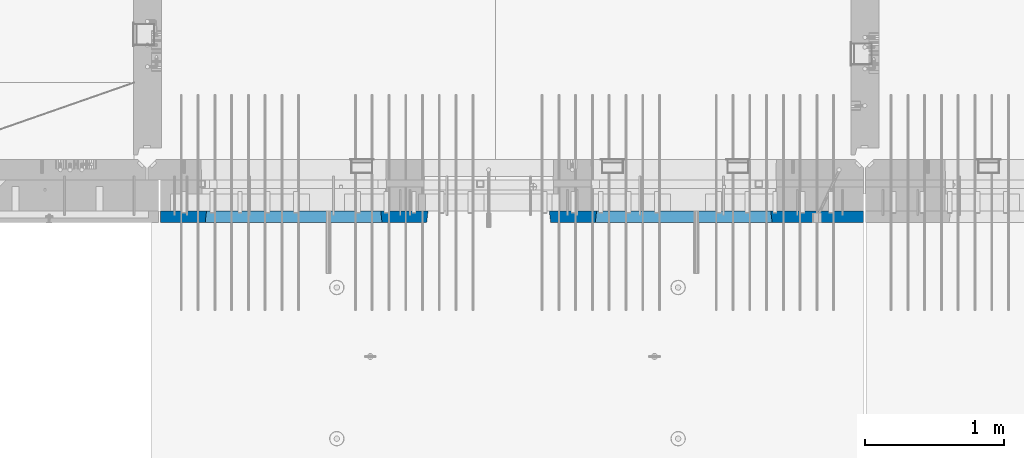
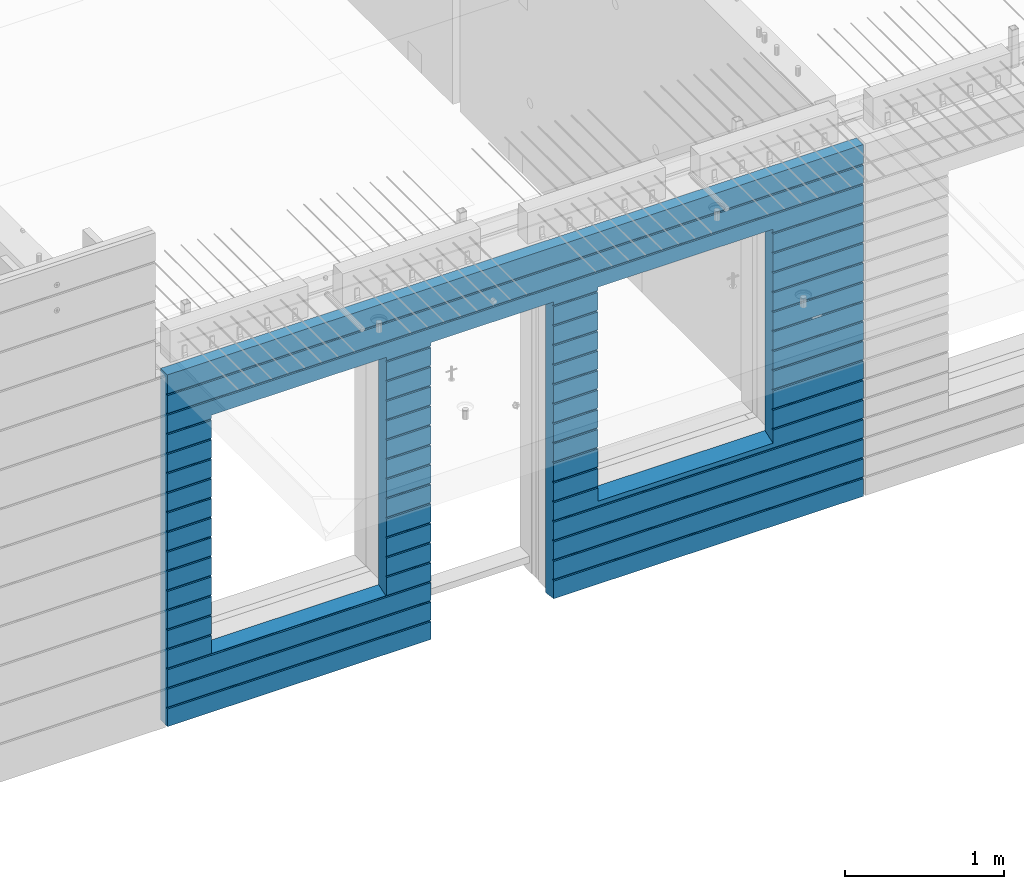
# One storey, part 196 of 309: 1 wall, 1 element without a shape of its own.
"""IFC2X3 building model written with IfcOpenShell, lengths in millimetres."""

from ifc_helpers import new_model, si_unit, frame, origin_with_axes, place, context, subcontext, project, spatial, faceted_brep, material, type_object, element, aggregate, save


model = new_model("IFC2X3")

# Units and contexts
model_context = context("Model", 3, precision=1e-05, world=origin_with_axes())
body_context = subcontext(model_context, "Body", "Model", "MODEL_VIEW")
ifc_project = project(units=[si_unit("LENGTHUNIT", "METRE", prefix="MILLI"), si_unit("AREAUNIT", "SQUARE_METRE"), si_unit("VOLUMEUNIT", "CUBIC_METRE"), si_unit("MASSUNIT", "GRAM", prefix="KILO"), si_unit("TIMEUNIT", "SECOND"), si_unit("PLANEANGLEUNIT", "RADIAN"), si_unit("SOLIDANGLEUNIT", "STERADIAN"), si_unit("THERMODYNAMICTEMPERATUREUNIT", "DEGREE_CELSIUS"), si_unit("LUMINOUSINTENSITYUNIT", "LUMEN")], contexts=[model_context])

# Site, building, storey
site_placement = place(None, origin_with_axes())
site = spatial("IfcSite", under=ifc_project, at=site_placement, CompositionType="ELEMENT")
building_placement = place(site_placement, origin_with_axes())
building = spatial("IfcBuilding", under=site, at=building_placement, CompositionType="ELEMENT")
storey_placement = place(building_placement, origin_with_axes())
storey = spatial("IfcBuildingStorey", under=building, at=storey_placement, Name="7", CompositionType="ELEMENT", Elevation=0.0)

# Assembly, wall
assembly_placement = place(storey_placement, origin_with_axes())
assembly = element("IfcElementAssembly", 1, at=assembly_placement, inside=storey, AssemblyPlace="NOTDEFINED", PredefinedType="REINFORCEMENT_UNIT")
ifc_material = material(Name="CONCRETE/C30/37")
wall_type = type_object("IfcWallType", PredefinedType="NOTDEFINED")
wall_placement = place(assembly_placement, frame((21810.0, 7587.5, 101102.5), z_axis=(0.0, 0.0, 1.0), x_axis=(-1.0, 3.00000001838171e-08, 0.0)))
wall = element("IfcWall", 2, at=wall_placement, type_object=wall_type, material=ifc_material, context=body_context, shape_type="Brep", body=[
    faceted_brep([(3465.15088791894, 41.2121213860573, -911.742424344746), (3464.99937278789, 42.5, -912.5), (3464.99937278789, 42.5, -912.000000055254), (4734.84785765683, 41.2121213860573, -911.742424344746), (4734.99937278789, 42.5, -912.5), (4734.99937278789, 42.5, -912.000000055254), (10.0, 42.5, -1347.5), (10.0, 42.5, -1212.00000005524), (2254.99845837354, 42.5, -1212.00000005524), (2254.99845837354, 42.5, -1347.5), (10.0, 32.4999992501662, -1210.00000000079), (2256.17512512844, 32.4999992501662, -1210.00000000079), (10.0000007500639, 32.499999249937, -1200.00000000079), (2256.17512514468, 32.4999991121731, -1199.99999959956), (10.0, 42.5, -1198.00000011075), (2254.99845837354, 42.5, -1198.00000011075), (10.0, 42.5, -1062.00000005522), (2254.99845837354, 42.5, -1062.00000005522), (10.0, 32.4999992506964, -1060.00000000079), (2256.17512512838, 32.4999992506964, -1060.00000000079), (10.0000007500657, 32.499999249937, -1050.00000000079), (2256.17512514461, 32.499999112697, -1049.99999959956), (10.0, 42.5, -1048.00000011074), (2254.99845837354, 42.5, -1048.00000011074), (10.0, 42.5, -912.000000055254), (2254.99845837354, 42.5, -912.000000055254), (10.0, 32.4999992512312, -910.000000000815), (2256.17512512832, 32.4999992512312, -910.000000000815), (10.0000007500657, 32.499999249937, -900.000000000786), (2256.17512514455, 32.4999991132318, -899.99999959959), (10.0, 42.5, -898.000000110769), (2254.99845837354, 42.5, -898.000000110769), (10.0, 42.5, -762.000000055225), (2254.99845837354, 42.5, -762.000000055225), (10.0, 32.4999992517696, -760.000000000771), (2256.17512512825, 32.4999992517696, -760.000000000771), (10.0000007500657, 32.499999249937, -750.000000000786), (2256.17512514449, 32.4999991137747, -749.999999599546), (10.0, 42.5, -748.00000011074), (2254.99845837354, 42.5, -748.00000011074), (675.00013572734, 42.5, 927.5), (1925.00013572734, 42.5, 927.5), (1935.00013572734, 42.5, 927.5), (1925.00013572734, -42.5, 932.5), (675.00013572734, -42.5, 932.5), (665.00013572734, 42.5, 927.5), (665.00013572734, 42.5, -712.5), (675.00013572734, -42.5, -662.5), (1925.00013572734, -42.5, -662.5), (1935.00013572734, 42.5, -712.5), (1925.00013572734, -42.5, 927.5), (1935.00013572734, 42.5, 901.999999889245), (1933.82366503463, 32.4999991119776, 900.000000400425), (1933.82366505087, 32.4999992499834, 889.9999999992), (1935.00013572734, 42.5, 887.999999944761), (1935.00013572734, 42.5, 751.999999889245), (1933.82366503463, 32.4999991119885, 750.000000400425), (1933.82366505087, 32.4999992499925, 739.9999999992), (1935.00013572734, 42.5, 737.999999944761), (1935.00013572734, 42.5, 601.99999988926), (1933.82366503463, 32.4999991120112, 600.00000040044), (1933.82366505087, 32.4999992500152, 589.999999999214), (1935.00013572734, 42.5, 587.999999944775), (1935.00013572734, 42.5, 451.999999889245), (1933.82366503464, 32.4999991120167, 450.000000400425), (1933.82366505087, 32.4999992500216, 439.9999999992), (1935.00013572734, 42.5, 437.999999944761), (1935.00013572734, 42.5, 301.999999889245), (1933.82366503464, 32.4999991120312, 300.000000400425), (1933.82366505087, 32.4999992500352, 289.9999999992), (1935.00013572734, 42.5, 287.999999944761), (1935.00013572734, 42.5, 151.999999889245), (1933.82366503464, 32.4999991120421, 150.000000400425), (1933.82366505088, 32.499999250047, 139.9999999992), (1935.00013572734, 42.5, 137.999999944761), (1935.00013572734, 42.5, 1.99999988923082), (1933.82366503515, 32.4999991164286, 4.00410499423742e-07), (1933.82366505139, 32.4999992544263, -10.0000000008149), (1935.00013572734, 42.5, -12.0000000552536), (1935.00013572734, 42.5, -148.000000110755), (1933.82366503509, 32.4999991158993, -149.99999959956), (1933.82366505132, 32.4999992538915, -160.000000000786), (1935.00013572734, 42.5, -162.000000055239), (1935.00013572734, 42.5, -298.000000110755), (1933.82366503503, 32.49999911536, -299.999999599575), (1933.82366505126, 32.4999992533594, -310.0000000008), (1935.00013572734, 42.5, -312.000000055239), (1935.00013572734, 42.5, -448.00000011074), (1933.82366503496, 32.4999991148343, -449.99999959956), (1933.8236650512, 32.4999992528337, -460.000000000786), (1935.00013572734, 42.5, -462.000000055225), (1935.00013572734, 42.5, -598.000000110755), (1933.8236650349, 32.499999114295, -599.999999599575), (1933.82366505114, 32.4999992522935, -610.0000000008), (1935.00013572734, 42.5, -612.000000055239), (2256.1751251447, 32.4999991119776, 900.000000400425), (2256.17512512846, 32.4999992499834, 889.9999999992), (2254.99845837354, 42.5, 887.999999944761), (2254.99845837354, 42.5, 751.999999889245), (2256.17512514469, 32.4999991119885, 750.000000400425), (2256.17512512846, 32.4999992499925, 739.9999999992), (2254.99845837354, 42.5, 737.999999944761), (2254.99845837354, 42.5, 601.99999988926), (2256.17512514469, 32.4999991120112, 600.00000040044), (2256.17512512846, 32.4999992500152, 589.999999999214), (2254.99845837354, 42.5, 587.999999944775), (2254.99845837354, 42.5, 451.999999889245), (2256.17512514469, 32.4999991120167, 450.000000400425), (2256.17512512846, 32.4999992500216, 439.9999999992), (2254.99845837354, 42.5, 437.999999944761), (2254.99845837354, 42.5, 301.999999889245), (2256.17512514469, 32.4999991120312, 300.000000400425), (2256.17512512846, 32.4999992500352, 289.9999999992), (2254.99845837354, 42.5, 287.999999944761), (2254.99845837354, 42.5, 151.999999889245), (2256.17512514469, 32.4999991120421, 150.000000400425), (2256.17512512846, 32.499999250047, 139.9999999992), (2254.99845837354, 42.5, 137.999999944761), (2254.99845837354, 42.5, 1.99999988923082), (2256.17512514417, 32.4999991164286, 4.00410499423742e-07), (2256.17512512794, 32.4999992544263, -10.0000000008149), (2254.99845837354, 42.5, -12.0000000552536), (2254.99845837354, 42.5, -148.000000110755), (2256.17512514424, 32.4999991158993, -149.99999959956), (2256.175125128, 32.4999992538915, -160.000000000786), (2254.99845837354, 42.5, -162.000000055239), (2254.99845837354, 42.5, -298.000000110755), (2256.1751251443, 32.49999911536, -299.999999599575), (2256.17512512806, 32.4999992533594, -310.0000000008), (2254.99845837354, 42.5, -312.000000055239), (2254.99845837354, 42.5, -448.00000011074), (2256.17512514436, 32.4999991148343, -449.99999959956), (2256.17512512813, 32.4999992528337, -460.000000000786), (2254.99845837354, 42.5, -462.000000055225), (2254.99845837354, 42.5, -598.000000110755), (2256.17512514443, 32.499999114295, -599.999999599575), (2256.17512512819, 32.4999992522935, -610.0000000008), (2254.99845837354, 42.5, -612.000000055239), (10.0, 42.5, -612.000000055239), (665.00013572734, 42.5, -612.000000055239), (10.0, 32.4999992522935, -610.0000000008), (666.176606403544, 32.4999992522935, -610.0000000008), (10.0000007500657, 32.499999249937, -600.000000000786), (666.176606419776, 32.499999114295, -599.999999599575), (10.0, 42.5, -598.000000110755), (665.00013572734, 42.5, -598.000000110755), (10.0, 42.5, -462.000000055225), (665.00013572734, 42.5, -462.000000055225), (10.0, 32.4999992528337, -460.000000000786), (666.176606403482, 32.4999992528337, -460.000000000786), (10.0000007500657, 32.499999249937, -450.000000000786), (666.176606419715, 32.4999991148343, -449.99999959956), (10.0, 42.5, -448.00000011074), (665.00013572734, 42.5, -448.00000011074), (10.0, 42.5, -312.000000055239), (665.00013572734, 42.5, -312.000000055239), (10.0, 32.4999992533594, -310.0000000008), (666.17660640342, 32.4999992533594, -310.0000000008), (10.0000007500657, 32.499999249937, -300.000000000786), (666.176606419653, 32.49999911536, -299.999999599575), (10.0, 42.5, -298.000000110755), (665.00013572734, 42.5, -298.000000110755), (10.0, 42.5, -162.000000055239), (665.00013572734, 42.5, -162.000000055239), (10.0, 32.4999992538915, -160.000000000786), (666.176606403355, 32.4999992538915, -160.000000000786), (10.0000007500657, 32.499999249937, -150.000000000786), (666.176606419591, 32.4999991158993, -149.99999959956), (10.0, 42.5, -148.000000110755), (665.00013572734, 42.5, -148.000000110755), (10.0, 42.5, -12.0000000552536), (665.00013572734, 42.5, -12.0000000552536), (10.0, 32.4999992544263, -10.0000000008149), (666.176606403293, 32.4999992544263, -10.0000000008149), (10.0000007500657, 32.499999249937, -7.8580342233181e-10), (666.176606419529, 32.4999991164286, 4.00410499423742e-07), (10.0, 42.5, 1.99999988923082), (665.00013572734, 42.5, 1.99999988923082), (10.0, 42.5, 137.999999944761), (665.00013572734, 42.5, 137.999999944761), (10.0, 32.499999250047, 139.9999999992), (666.176606403806, 32.499999250047, 139.9999999992), (10.0000007500657, 32.499999249937, 149.999999999214), (666.176606420046, 32.4999991120421, 150.000000400425), (10.0, 42.5, 151.999999889245), (665.00013572734, 42.5, 151.999999889245), (10.0, 42.5, 287.999999944761), (665.00013572734, 42.5, 287.999999944761), (10.0, 32.4999992500352, 289.9999999992), (666.176606403809, 32.4999992500352, 289.9999999992), (10.0000007500657, 32.499999249937, 299.999999999214), (666.176606420046, 32.4999991120312, 300.000000400425), (10.0, 42.5, 301.999999889245), (665.00013572734, 42.5, 301.999999889245), (10.0, 42.5, 437.999999944761), (665.00013572734, 42.5, 437.999999944761), (10.0, 32.4999992500216, 439.9999999992), (666.176606403809, 32.4999992500216, 439.9999999992), (10.0000007500657, 32.499999249937, 449.999999999214), (666.176606420046, 32.4999991120167, 450.000000400425), (10.0, 42.5, 451.999999889245), (665.00013572734, 42.5, 451.999999889245), (10.0, 42.5, 587.999999944775), (665.00013572734, 42.5, 587.999999944775), (10.0, 32.4999992500152, 589.999999999214), (666.176606403809, 32.4999992500152, 589.999999999214), (10.0000007500657, 32.499999249937, 599.999999999214), (666.176606420049, 32.4999991120112, 600.00000040044), (10.0, 42.5, 601.99999988926), (665.00013572734, 42.5, 601.99999988926), (10.0, 42.5, 737.999999944761), (665.00013572734, 42.5, 737.999999944761), (9.99999999999636, 32.4999992499925, 739.9999999992), (666.176606403813, 32.4999992499925, 739.9999999992), (10.0000007500657, 32.499999249937, 749.999999999214), (666.176606420049, 32.4999991119885, 750.000000400425), (10.0, 42.5, 751.999999889245), (665.00013572734, 42.5, 751.999999889245), (10.0, 42.5, 887.999999944761), (665.00013572734, 42.5, 887.999999944761), (10.0, 32.4999992499834, 889.9999999992), (666.176606403813, 32.4999992499834, 889.9999999992), (10.0000007500657, 32.499999249937, 899.999999999214), (666.176606420053, 32.4999991119776, 900.000000400425), (675.00013572734, -42.5, 927.5), (665.00013572734, 42.5, 901.999999889245), (10.0, 42.5, 901.999999889245), (10.0, 42.5, 1051.99999988925), (5055.0, 42.5, 1051.99999988925), (5055.0, 32.4999991119666, 1050.00000040043), (10.0000007500657, 32.499999249937, 1049.99999999921), (5055.0, 32.4999992499706, 1039.9999999992), (10.0, 32.4999992499706, 1039.9999999992), (5055.0, 42.5, 1037.99999994476), (10.0, 42.5, 1037.99999994476), (5055.0, 42.5, 901.999999889245), (5055.0, 32.4999991119776, 900.000000400425), (4733.82290209518, 32.4999991119776, 900.000000400425), (4734.99937278789, 42.5, 901.999999889245), (5055.0, 32.4999992499834, 889.9999999992), (4733.82290211141, 32.4999992499834, 889.9999999992), (5055.0, 42.5, 887.999999944761), (4734.99937278789, 42.5, 887.999999944761), (5055.0, 42.5, 751.999999889245), (4734.99937278789, 42.5, 751.999999889245), (5055.0, 32.4999991119885, 750.000000400425), (4733.82290209518, 32.4999991119885, 750.000000400425), (5055.0, 32.4999992499925, 739.9999999992), (4733.82290211142, 32.4999992499925, 739.9999999992), (5055.0, 42.5, 737.999999944761), (4734.99937278789, 42.5, 737.999999944761), (5055.0, 42.5, 601.99999988926), (4734.99937278789, 42.5, 601.99999988926), (5055.0, 32.4999991120112, 600.00000040044), (4733.82290209518, 32.4999991120112, 600.00000040044), (5055.0, 32.4999992500152, 589.999999999214), (4733.82290211142, 32.4999992500152, 589.999999999214), (5055.0, 42.5, 587.999999944775), (4734.99937278789, 42.5, 587.999999944775), (5055.0, 42.5, 451.999999889245), (4734.99937278789, 42.5, 451.999999889245), (5055.0, 32.4999991120167, 450.000000400425), (4733.82290209518, 32.4999991120167, 450.000000400425), (5055.0, 32.4999992500216, 439.9999999992), (4733.82290211142, 32.4999992500216, 439.9999999992), (5055.0, 42.5, 437.999999944761), (4734.99937278789, 42.5, 437.999999944761), (5055.0, 42.5, 301.999999889245), (4734.99937278789, 42.5, 301.999999889245), (5055.0, 32.4999991120312, 300.000000400425), (4733.82290209518, 32.4999991120312, 300.000000400425), (5055.0, 32.4999992500352, 289.9999999992), (4733.82290211142, 32.4999992500352, 289.9999999992), (5055.0, 42.5, 287.999999944761), (4734.99937278789, 42.5, 287.999999944761), (5055.0, 42.5, 151.999999889245), (4734.99937278789, 42.5, 151.999999889245), (5055.0, 32.4999991120421, 150.000000400425), (4733.82290209519, 32.4999991120421, 150.000000400425), (5055.0, 32.499999250047, 139.9999999992), (4733.82290211142, 32.499999250047, 139.9999999992), (5055.0, 42.5, 137.999999944761), (4734.99937278789, 42.5, 137.999999944761), (5055.0, 42.5, 1.99999988923082), (4734.99937278789, 42.5, 1.99999988923082), (5055.0, 32.4999991164286, 4.00410499423742e-07), (4733.8229020957, 32.4999991164286, 4.00410499423742e-07), (5055.0, 32.4999992544263, -10.0000000008149), (4733.82290211194, 32.4999992544263, -10.0000000008149), (5055.0, 42.5, -12.0000000552536), (4734.99937278789, 42.5, -12.0000000552536), (5055.0, 42.5, -148.000000110755), (4734.99937278789, 42.5, -148.000000110755), (5055.0, 32.4999991158993, -149.99999959956), (4733.82290209564, 32.4999991158993, -149.99999959956), (5055.0, 32.4999992538915, -160.000000000786), (4733.82290211188, 32.4999992538915, -160.000000000786), (5055.0, 42.5, -162.000000055239), (4734.99937278789, 42.5, -162.000000055239), (5055.0, 42.5, -298.000000110755), (4734.99937278789, 42.5, -298.000000110755), (5055.0, 32.49999911536, -299.999999599575), (4733.82290209558, 32.49999911536, -299.999999599575), (5055.0, 32.4999992533594, -310.0000000008), (4733.82290211181, 32.4999992533594, -310.0000000008), (5055.0, 42.5, -312.000000055239), (4734.99937278789, 42.5, -312.000000055239), (5055.0, 42.5, -448.00000011074), (4734.99937278789, 42.5, -448.00000011074), (5055.0, 32.4999991148343, -449.99999959956), (4733.82290209552, 32.4999991148343, -449.99999959956), (5055.0, 32.4999992528337, -460.000000000786), (4733.82290211175, 32.4999992528337, -460.000000000786), (5055.0, 42.5, -462.000000055225), (4734.99937278789, 42.5, -462.000000055225), (5055.0, 42.5, -598.000000110755), (4734.99937278789, 42.5, -598.000000110755), (5055.0, 32.499999114295, -599.999999599575), (4733.82290209545, 32.499999114295, -599.999999599575), (5055.0, 32.4999992522935, -610.0000000008), (4733.82290211169, 32.4999992522935, -610.0000000008), (5055.0, 42.5, -612.000000055239), (4734.99937278789, 42.5, -612.000000055239), (5055.0, 42.5, -748.00000011074), (4734.99937278789, 42.5, -748.00000011074), (5055.0, 32.4999991137747, -749.999999599546), (4733.82290209539, 32.4999991137747, -749.999999599546), (5055.0, 32.4999992517696, -760.000000000771), (4733.82290211162, 32.4999992517696, -760.000000000771), (5055.0, 42.5, -762.000000055225), (4734.99937278789, 42.5, -762.000000055225), (5055.0, 42.5, -898.000000110769), (4734.99937278789, 42.5, -898.000000110769), (5055.0, 32.4999991132318, -899.99999959959), (4733.82290209533, 32.4999991132318, -899.99999959959), (3466.1758434697, 32.499999204555, -906.617646590923), (3474.99937278789, -42.5, -862.5), (4724.99937278789, -42.5, -862.5), (4733.82290210607, 32.499999204555, -906.617646590923), (4724.99937278789, -42.5, 927.5), (4724.99937278789, -42.5, 932.5), (4734.99937278789, 42.5, 927.5), (2265.00051719707, 42.5, 927.5), (3135.00051719707, 42.5, 927.5), (3144.99845837354, 42.5, 927.5), (3134.99679170688, -42.5, 932.502857142856), (2265.00012504021, -42.5, 932.502857142856), (2254.99845837354, 42.5, 927.5), (4724.99937278789, 42.5, 927.5), (3474.99937278789, 42.5, 927.5), (3464.99937278789, 42.5, 927.5), (3464.99937278789, 42.5, 901.999999889245), (3144.99845837354, 42.5, 901.999999889245), (2254.99845837354, 42.5, 901.999999889245), (2265.00012504021, -42.5, 927.5), (2265.00012504021, -42.5, -1347.5), (10.0, -42.5, -1347.5), (10.0, 42.5, 1347.5), (10.0, -42.5, 1347.5), (5055.0, -42.5, 1347.5), (5055.0, 42.5, 1347.5), (5055.0, 42.5, 1201.99999988925), (10.0, 42.5, 1201.99999988925), (10.0, 42.5, 1187.99999994476), (10.0000007500657, 32.499999249937, 1199.99999999921), (9.99999999999636, 32.4999992499606, 1189.9999999992), (5055.0, 42.5, 1187.99999994476), (5055.0, 32.4999992499606, 1189.9999999992), (5055.0, 32.4999991119566, 1200.00000040043), (5055.0, -42.5, -1347.5), (5055.0, 42.5, -1347.5), (5055.0, 42.5, -1212.00000005524), (5055.0, 32.4999992501662, -1210.00000000079), (5055.0, 32.4999991121731, -1199.99999959956), (5055.0, 42.5, -1198.00000011075), (5055.0, 42.5, -1062.00000005522), (5055.0, 32.4999992506964, -1060.00000000079), (5055.0, 32.499999112697, -1049.99999959956), (5055.0, 42.5, -1048.00000011074), (5055.0, 42.5, -912.000000055254), (5055.0, 32.4999992512312, -910.000000000815), (3144.99845837354, 42.5, -1212.00000005524), (3143.82179161865, 32.4999992501662, -1210.00000000079), (3143.82179160241, 32.4999991121731, -1199.99999959956), (3144.99845837354, 42.5, -1198.00000011075), (3144.99845837354, 42.5, -1062.00000005522), (3143.82179161871, 32.4999992506964, -1060.00000000079), (3143.82179160247, 32.499999112697, -1049.99999959956), (3144.99845837354, 42.5, -1048.00000011074), (3144.99845837354, 42.5, -912.000000055254), (3143.82179161877, 32.4999992512312, -910.000000000815), (3466.17584348045, 32.4999991132318, -899.99999959959), (3143.82179160253, 32.4999991132318, -899.99999959959), (3464.99937278789, 42.5, -898.000000110769), (3144.99845837354, 42.5, -898.000000110769), (3464.99937278789, 42.5, -762.000000055225), (3144.99845837354, 42.5, -762.000000055225), (3466.17584346415, 32.4999992517696, -760.000000000771), (3143.82179161884, 32.4999992517696, -760.000000000771), (3466.17584348039, 32.4999991137747, -749.999999599546), (3143.8217916026, 32.4999991137747, -749.999999599546), (3464.99937278789, 42.5, -748.00000011074), (3144.99845837354, 42.5, -748.00000011074), (3464.99937278789, 42.5, -612.000000055239), (3144.99845837354, 42.5, -612.000000055239), (3466.17584346409, 32.4999992522935, -610.0000000008), (3143.8217916189, 32.4999992522935, -610.0000000008), (3466.17584348032, 32.499999114295, -599.999999599575), (3143.82179160266, 32.499999114295, -599.999999599575), (3464.99937278789, 42.5, -598.000000110755), (3144.99845837354, 42.5, -598.000000110755), (3464.99937278789, 42.5, -462.000000055225), (3144.99845837354, 42.5, -462.000000055225), (3466.17584346403, 32.4999992528337, -460.000000000786), (3143.82179161896, 32.4999992528337, -460.000000000786), (3466.17584348026, 32.4999991148343, -449.99999959956), (3143.82179160272, 32.4999991148343, -449.99999959956), (3464.99937278789, 42.5, -448.00000011074), (3144.99845837354, 42.5, -448.00000011074), (3464.99937278789, 42.5, -312.000000055239), (3144.99845837354, 42.5, -312.000000055239), (3466.17584346396, 32.4999992533594, -310.0000000008), (3143.82179161902, 32.4999992533594, -310.0000000008), (3466.1758434802, 32.49999911536, -299.999999599575), (3143.82179160278, 32.49999911536, -299.999999599575), (3464.99937278789, 42.5, -298.000000110755), (3144.99845837354, 42.5, -298.000000110755), (3464.99937278789, 42.5, -162.000000055239), (3144.99845837354, 42.5, -162.000000055239), (3466.1758434639, 32.4999992538915, -160.000000000786), (3143.82179161909, 32.4999992538915, -160.000000000786), (3466.17584348014, 32.4999991158993, -149.99999959956), (3143.82179160284, 32.4999991158993, -149.99999959956), (3464.99937278789, 42.5, -148.000000110755), (3144.99845837354, 42.5, -148.000000110755), (3464.99937278789, 42.5, -12.0000000552536), (3144.99845837354, 42.5, -12.0000000552536), (3466.17584346384, 32.4999992544263, -10.0000000008149), (3143.82179161915, 32.4999992544263, -10.0000000008149), (3466.17584348008, 32.4999991164286, 4.00410499423742e-07), (3143.82179160291, 32.4999991164286, 4.00410499423742e-07), (3464.99937278789, 42.5, 1.99999988923082), (3144.99845837354, 42.5, 1.99999988923082), (3464.99937278789, 42.5, 137.999999944761), (3144.99845837354, 42.5, 137.999999944761), (3466.17584346435, 32.499999250047, 139.9999999992), (3143.82179161863, 32.499999250047, 139.9999999992), (3466.17584348059, 32.4999991120421, 150.000000400425), (3143.82179160239, 32.4999991120421, 150.000000400425), (3464.99937278789, 42.5, 151.999999889245), (3144.99845837354, 42.5, 151.999999889245), (3464.99937278789, 42.5, 287.999999944761), (3144.99845837354, 42.5, 287.999999944761), (3466.17584346436, 32.4999992500352, 289.9999999992), (3143.82179161863, 32.4999992500352, 289.9999999992), (3466.17584348059, 32.4999991120312, 300.000000400425), (3143.82179160239, 32.4999991120312, 300.000000400425), (3464.99937278789, 42.5, 301.999999889245), (3144.99845837354, 42.5, 301.999999889245), (3464.99937278789, 42.5, 437.999999944761), (3144.99845837354, 42.5, 437.999999944761), (3466.17584346436, 32.4999992500216, 439.9999999992), (3143.82179161863, 32.4999992500216, 439.9999999992), (3466.17584348059, 32.4999991120167, 450.000000400425), (3143.82179160239, 32.4999991120167, 450.000000400425), (3464.99937278789, 42.5, 451.999999889245), (3144.99845837354, 42.5, 451.999999889245), (3464.99937278789, 42.5, 587.999999944775), (3144.99845837354, 42.5, 587.999999944775), (3466.17584346436, 32.4999992500152, 589.999999999214), (3143.82179161863, 32.4999992500152, 589.999999999214), (3466.1758434806, 32.4999991120112, 600.00000040044), (3143.82179160239, 32.4999991120112, 600.00000040044), (3464.99937278789, 42.5, 601.99999988926), (3144.99845837354, 42.5, 601.99999988926), (3464.99937278789, 42.5, 737.999999944761), (3144.99845837354, 42.5, 737.999999944761), (3466.17584346436, 32.4999992499925, 739.9999999992), (3143.82179161863, 32.4999992499925, 739.9999999992), (3466.1758434806, 32.4999991119885, 750.000000400425), (3143.82179160239, 32.4999991119885, 750.000000400425), (3464.99937278789, 42.5, 751.999999889245), (3144.99845837354, 42.5, 751.999999889245), (3464.99937278789, 42.5, 887.999999944761), (3144.99845837354, 42.5, 887.999999944761), (3466.17584346436, 32.4999992499834, 889.9999999992), (3143.82179161863, 32.4999992499834, 889.9999999992), (3466.1758434806, 32.4999991119776, 900.000000400425), (3143.82179160239, 32.4999991119776, 900.000000400425), (3474.99937278789, -42.5, 932.5), (3474.99937278789, -42.5, 927.5), (3134.99679170688, -42.5, 927.5), (3134.99679170688, -42.5, -1347.5), (3144.99845837354, 42.5, -1347.5)], [[[0, 1, 2]], [[3, 4, 1, 0]], [[5, 4, 3]], [[6, 7, 8, 9]], [[7, 10, 11, 8]], [[10, 12, 13, 11]], [[12, 14, 15, 13]], [[14, 16, 17, 15]], [[16, 18, 19, 17]], [[18, 20, 21, 19]], [[20, 22, 23, 21]], [[22, 24, 25, 23]], [[24, 26, 27, 25]], [[26, 28, 29, 27]], [[28, 30, 31, 29]], [[30, 32, 33, 31]], [[32, 34, 35, 33]], [[34, 36, 37, 35]], [[36, 38, 39, 37]], [[40, 41, 42, 43, 44, 45]], [[46, 47, 48, 49]], [[50, 43, 42, 51, 52, 53, 54, 55, 56, 57, 58, 59, 60, 61, 62, 63, 64, 65, 66, 67, 68, 69, 70, 71, 72, 73, 74, 75, 76, 77, 78, 79, 80, 81, 82, 83, 84, 85, 86, 87, 88, 89, 90, 91, 92, 93, 94, 49, 48]], [[53, 52, 95, 96]], [[54, 53, 96, 97]], [[55, 54, 97, 98]], [[56, 55, 98, 99]], [[57, 56, 99, 100]], [[58, 57, 100, 101]], [[59, 58, 101, 102]], [[60, 59, 102, 103]], [[61, 60, 103, 104]], [[62, 61, 104, 105]], [[63, 62, 105, 106]], [[64, 63, 106, 107]], [[65, 64, 107, 108]], [[66, 65, 108, 109]], [[67, 66, 109, 110]], [[68, 67, 110, 111]], [[69, 68, 111, 112]], [[70, 69, 112, 113]], [[71, 70, 113, 114]], [[72, 71, 114, 115]], [[73, 72, 115, 116]], [[74, 73, 116, 117]], [[75, 74, 117, 118]], [[76, 75, 118, 119]], [[77, 76, 119, 120]], [[78, 77, 120, 121]], [[79, 78, 121, 122]], [[80, 79, 122, 123]], [[81, 80, 123, 124]], [[82, 81, 124, 125]], [[83, 82, 125, 126]], [[84, 83, 126, 127]], [[85, 84, 127, 128]], [[86, 85, 128, 129]], [[87, 86, 129, 130]], [[88, 87, 130, 131]], [[89, 88, 131, 132]], [[90, 89, 132, 133]], [[91, 90, 133, 134]], [[92, 91, 134, 135]], [[93, 92, 135, 136]], [[94, 93, 136, 137]], [[38, 138, 139, 46, 49, 94, 137, 39]], [[138, 140, 141, 139]], [[140, 142, 143, 141]], [[142, 144, 145, 143]], [[144, 146, 147, 145]], [[146, 148, 149, 147]], [[148, 150, 151, 149]], [[150, 152, 153, 151]], [[152, 154, 155, 153]], [[154, 156, 157, 155]], [[156, 158, 159, 157]], [[158, 160, 161, 159]], [[160, 162, 163, 161]], [[162, 164, 165, 163]], [[164, 166, 167, 165]], [[166, 168, 169, 167]], [[168, 170, 171, 169]], [[170, 172, 173, 171]], [[172, 174, 175, 173]], [[174, 176, 177, 175]], [[176, 178, 179, 177]], [[178, 180, 181, 179]], [[180, 182, 183, 181]], [[182, 184, 185, 183]], [[184, 186, 187, 185]], [[186, 188, 189, 187]], [[188, 190, 191, 189]], [[190, 192, 193, 191]], [[192, 194, 195, 193]], [[194, 196, 197, 195]], [[196, 198, 199, 197]], [[198, 200, 201, 199]], [[200, 202, 203, 201]], [[202, 204, 205, 203]], [[204, 206, 207, 205]], [[206, 208, 209, 207]], [[208, 210, 211, 209]], [[210, 212, 213, 211]], [[212, 214, 215, 213]], [[214, 216, 217, 215]], [[216, 218, 219, 217]], [[218, 220, 221, 219]], [[220, 222, 223, 221]], [[45, 44, 224, 47, 46, 139, 141, 143, 145, 147, 149, 151, 153, 155, 157, 159, 161, 163, 165, 167, 169, 171, 173, 175, 177, 179, 181, 183, 185, 187, 189, 191, 193, 195, 197, 199, 201, 203, 205, 207, 209, 211, 213, 215, 217, 219, 221, 223, 225]], [[222, 226, 225, 223]], [[227, 228, 229, 230]], [[230, 229, 231, 232]], [[232, 231, 233, 234]], [[235, 236, 237, 238]], [[236, 239, 240, 237]], [[239, 241, 242, 240]], [[241, 243, 244, 242]], [[243, 245, 246, 244]], [[245, 247, 248, 246]], [[247, 249, 250, 248]], [[249, 251, 252, 250]], [[251, 253, 254, 252]], [[253, 255, 256, 254]], [[255, 257, 258, 256]], [[257, 259, 260, 258]], [[259, 261, 262, 260]], [[261, 263, 264, 262]], [[263, 265, 266, 264]], [[265, 267, 268, 266]], [[267, 269, 270, 268]], [[269, 271, 272, 270]], [[271, 273, 274, 272]], [[273, 275, 276, 274]], [[275, 277, 278, 276]], [[277, 279, 280, 278]], [[279, 281, 282, 280]], [[281, 283, 284, 282]], [[283, 285, 286, 284]], [[285, 287, 288, 286]], [[287, 289, 290, 288]], [[289, 291, 292, 290]], [[291, 293, 294, 292]], [[293, 295, 296, 294]], [[295, 297, 298, 296]], [[297, 299, 300, 298]], [[299, 301, 302, 300]], [[301, 303, 304, 302]], [[303, 305, 306, 304]], [[305, 307, 308, 306]], [[307, 309, 310, 308]], [[309, 311, 312, 310]], [[311, 313, 314, 312]], [[313, 315, 316, 314]], [[315, 317, 318, 316]], [[317, 319, 320, 318]], [[319, 321, 322, 320]], [[321, 323, 324, 322]], [[323, 325, 326, 324]], [[325, 327, 328, 326]], [[327, 329, 330, 328]], [[329, 331, 332, 330]], [[331, 333, 334, 332]], [[335, 336, 337, 338]], [[339, 340, 341, 238, 237, 240, 242, 244, 246, 248, 250, 252, 254, 256, 258, 260, 262, 264, 266, 268, 270, 272, 274, 276, 278, 280, 282, 284, 286, 288, 290, 292, 294, 296, 298, 300, 302, 304, 306, 308, 310, 312, 314, 316, 318, 320, 322, 324, 326, 328, 330, 332, 334, 338, 337]], [[342, 343, 344, 345, 346, 347]], [[51, 42, 41, 40, 45, 225, 226, 234, 233, 235, 238, 341, 348, 349, 350, 351, 352, 344, 343, 342, 347, 353]], [[52, 51, 353, 95]], [[347, 346, 354, 355, 9, 8, 11, 13, 15, 17, 19, 21, 23, 25, 27, 29, 31, 33, 35, 37, 39, 137, 136, 135, 134, 133, 132, 131, 130, 129, 128, 127, 126, 125, 124, 123, 122, 121, 120, 119, 118, 117, 116, 115, 114, 113, 112, 111, 110, 109, 108, 107, 106, 105, 104, 103, 102, 101, 100, 99, 98, 97, 96, 95, 353]], [[356, 6, 9, 355]], [[357, 358, 359, 360]], [[357, 360, 361, 362]], [[363, 227, 230, 232, 234, 226, 222, 220, 218, 216, 214, 212, 210, 208, 206, 204, 202, 200, 198, 196, 194, 192, 190, 188, 186, 184, 182, 180, 178, 176, 174, 172, 170, 168, 166, 164, 162, 160, 158, 156, 154, 152, 150, 148, 146, 144, 142, 140, 138, 38, 36, 34, 32, 30, 28, 26, 24, 22, 20, 18, 16, 14, 12, 10, 7, 6, 356, 358, 357, 362, 364, 365]], [[228, 227, 363, 366]], [[365, 367, 366, 363]], [[364, 368, 367, 365]], [[362, 361, 368, 364]], [[360, 359, 369, 370, 371, 372, 373, 374, 375, 376, 377, 378, 379, 380, 333, 331, 329, 327, 325, 323, 321, 319, 317, 315, 313, 311, 309, 307, 305, 303, 301, 299, 297, 295, 293, 291, 289, 287, 285, 283, 281, 279, 277, 275, 273, 271, 269, 267, 265, 263, 261, 259, 257, 255, 253, 251, 249, 247, 245, 243, 241, 239, 236, 235, 233, 231, 229, 228, 366, 367, 368, 361]], [[372, 371, 381, 382]], [[373, 372, 382, 383]], [[374, 373, 383, 384]], [[375, 374, 384, 385]], [[376, 375, 385, 386]], [[377, 376, 386, 387]], [[378, 377, 387, 388]], [[2, 1, 4, 5, 379, 378, 388, 389]], [[380, 379, 5, 3, 0, 2, 389, 390]], [[391, 335, 338, 334, 333, 380, 390, 392]], [[393, 391, 392, 394]], [[395, 393, 394, 396]], [[397, 395, 396, 398]], [[399, 397, 398, 400]], [[401, 399, 400, 402]], [[403, 401, 402, 404]], [[405, 403, 404, 406]], [[407, 405, 406, 408]], [[409, 407, 408, 410]], [[411, 409, 410, 412]], [[413, 411, 412, 414]], [[415, 413, 414, 416]], [[417, 415, 416, 418]], [[419, 417, 418, 420]], [[421, 419, 420, 422]], [[423, 421, 422, 424]], [[425, 423, 424, 426]], [[427, 425, 426, 428]], [[429, 427, 428, 430]], [[431, 429, 430, 432]], [[433, 431, 432, 434]], [[435, 433, 434, 436]], [[437, 435, 436, 438]], [[439, 437, 438, 440]], [[441, 439, 440, 442]], [[443, 441, 442, 444]], [[445, 443, 444, 446]], [[447, 445, 446, 448]], [[449, 447, 448, 450]], [[451, 449, 450, 452]], [[453, 451, 452, 454]], [[455, 453, 454, 456]], [[457, 455, 456, 458]], [[459, 457, 458, 460]], [[461, 459, 460, 462]], [[463, 461, 462, 464]], [[465, 463, 464, 466]], [[467, 465, 466, 468]], [[469, 467, 468, 470]], [[471, 469, 470, 472]], [[473, 471, 472, 474]], [[475, 473, 474, 476]], [[477, 475, 476, 478]], [[479, 477, 478, 480]], [[481, 479, 480, 482]], [[483, 481, 482, 484]], [[485, 483, 484, 486]], [[487, 485, 486, 488]], [[351, 487, 488, 352]], [[350, 489, 490, 336, 335, 391, 393, 395, 397, 399, 401, 403, 405, 407, 409, 411, 413, 415, 417, 419, 421, 423, 425, 427, 429, 431, 433, 435, 437, 439, 441, 443, 445, 447, 449, 451, 453, 455, 457, 459, 461, 463, 465, 467, 469, 471, 473, 475, 477, 479, 481, 483, 485, 487, 351]], [[349, 348, 341, 340, 489, 350]], [[491, 492, 369, 359, 358, 356, 355, 354, 346, 345], [339, 337, 336, 490, 489, 340], [50, 48, 47, 224, 44, 43]], [[370, 369, 492, 493]], [[491, 345, 344, 352, 488, 486, 484, 482, 480, 478, 476, 474, 472, 470, 468, 466, 464, 462, 460, 458, 456, 454, 452, 450, 448, 446, 444, 442, 440, 438, 436, 434, 432, 430, 428, 426, 424, 422, 420, 418, 416, 414, 412, 410, 408, 406, 404, 402, 400, 398, 396, 394, 392, 390, 389, 388, 387, 386, 385, 384, 383, 382, 381, 493, 492]], [[371, 370, 493, 381]]]),
])
aggregate(assembly, [wall])

save(model, "model.ifc")
